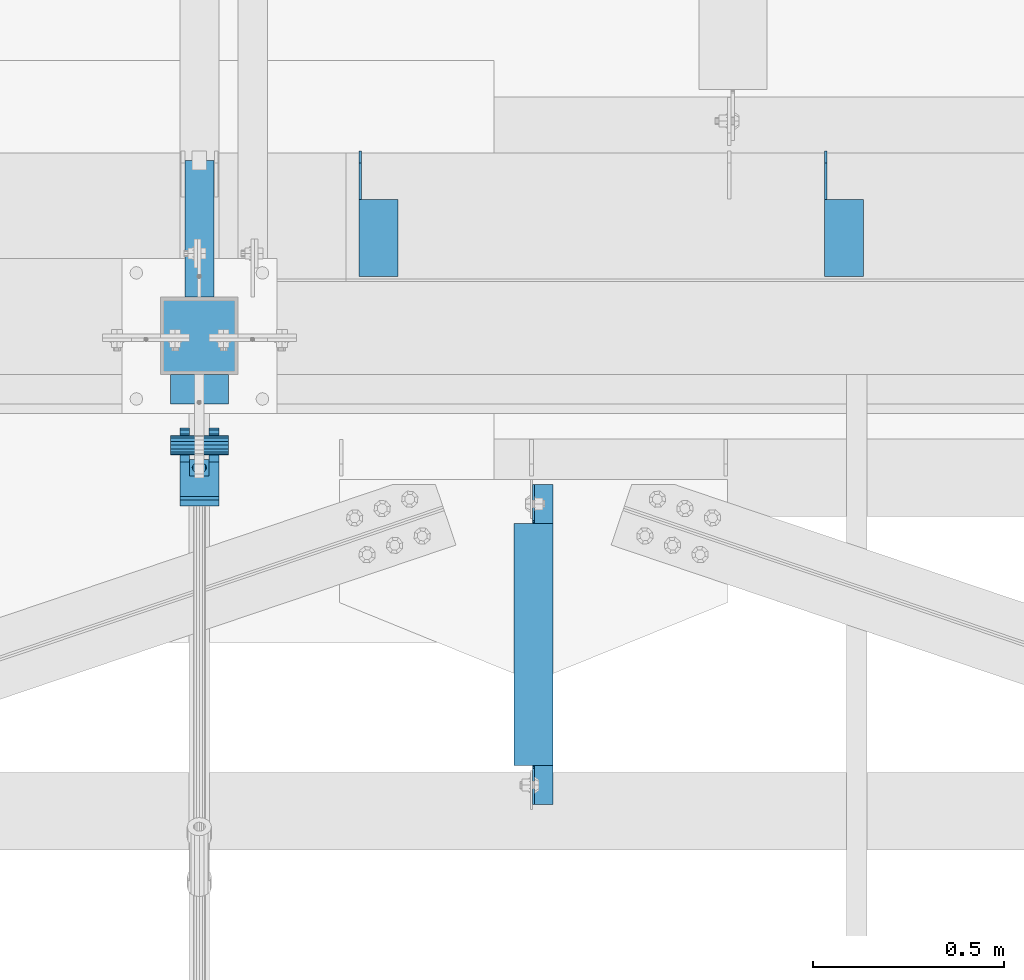
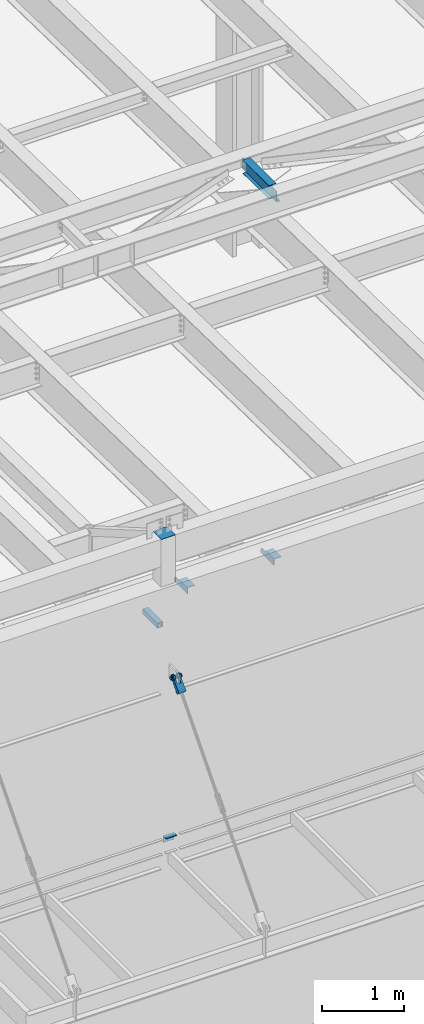
# One storey, part 1203 of 1763: 7 beams, 1 member, 6 elements without a shape of their own.
"""IFC2X3 building model written with IfcOpenShell, lengths in millimetres."""

from ifc_helpers import new_model, si_unit, frame, origin_with_axes, place, context, subcontext, project, spatial, faceted_brep, material, type_object, element, aggregate, save


model = new_model("IFC2X3")

# Units and contexts
model_context = context("Model", 3, precision=1e-05, world=origin_with_axes())
body_context = subcontext(model_context, "Body", "Model", "MODEL_VIEW")
ifc_project = project(units=[si_unit("LENGTHUNIT", "METRE", prefix="MILLI"), si_unit("AREAUNIT", "SQUARE_METRE"), si_unit("VOLUMEUNIT", "CUBIC_METRE"), si_unit("MASSUNIT", "GRAM", prefix="KILO"), si_unit("TIMEUNIT", "SECOND"), si_unit("PLANEANGLEUNIT", "RADIAN"), si_unit("SOLIDANGLEUNIT", "STERADIAN"), si_unit("THERMODYNAMICTEMPERATUREUNIT", "DEGREE_CELSIUS"), si_unit("LUMINOUSINTENSITYUNIT", "LUMEN")], contexts=[model_context])

# Site, building, storey
site_placement = place(None, origin_with_axes())
site = spatial("IfcSite", under=ifc_project, at=site_placement, CompositionType="ELEMENT")
building_placement = place(site_placement, origin_with_axes())
building = spatial("IfcBuilding", under=site, at=building_placement, Name="Undefined", CompositionType="ELEMENT")
storey_placement = place(building_placement, origin_with_axes())
storey = spatial("IfcBuildingStorey", under=building, at=storey_placement, Name="Undefined", CompositionType="ELEMENT", Elevation=0.0)

# Assembly, beams
assembly_1_placement = place(storey_placement, origin_with_axes())
assembly_1 = element("IfcElementAssembly", 1, at=assembly_1_placement, inside=storey, Name="BEAM", AssemblyPlace="NOTDEFINED", PredefinedType="RIGID_FRAME")
ifc_material_1 = material(Name="STEEL/A36")
beam_type_1 = type_object("IfcBeamType", Name="L4X4X1/4", PredefinedType="NOTDEFINED")
beam_1_placement = place(assembly_1_placement, frame((-57239.2055562795, -13723.1435701432, 12153.9), z_axis=(0.0, 0.0, -1.0), x_axis=(0.0, -1.0, 0.0)))
beam_1 = element("IfcBeam", 2, at=beam_1_placement, type_object=beam_type_1, material=ifc_material_1, Name="BRACE", ObjectType="L4X4X1/4", context=body_context, shape_type="Brep", body=[
    faceted_brep([(127.793748474227, 44.4499999999971, -31.7500007627295), (127.793748474227, 50.8000000000029, -31.7500007627295), (127.793748474225, 50.8000000000029, -50.7999999999993), (127.793748474225, -50.8000000000029, -50.7999999999993), (127.793748474225, -50.8000000000029, -44.4500000000007), (127.793748474225, 44.4499999999971, -44.4500000000007), (31.7499999999673, 44.4499999999971, -31.7500001906901), (31.7499999999673, 50.8000000000029, -31.7500007627295), (-1.81898940354586e-10, 44.4500000000371, 50.7999999999374), (-1.96450855582952e-10, 50.8000000000393, 50.7999999999374), (0.0, 50.8000000000029, -1.90690116141923e-07), (0.0, 44.4499999999971, -1.90690116141923e-07), (329.406260681253, 44.4499999999971, 50.7999999999993), (329.406260681253, 50.8000000000029, 50.7999999999993), (329.406260681253, 44.4499999999971, -44.4500000000007), (329.406260681253, -50.8000000000029, -44.4500000000007), (329.406260681253, -50.8000000000029, -50.7999999999993), (329.406260681253, 50.8000000000029, -50.7999999999993)], [[[0, 1, 2, 3, 4, 5]], [[1, 0, 6, 7]], [[8, 9, 10, 11]], [[9, 8, 12, 13]], [[12, 14, 15, 16, 17, 13]], [[15, 14, 5, 4]], [[16, 15, 4, 3]], [[17, 16, 3, 2]], [[9, 13, 17, 2, 1, 7, 10]], [[6, 11, 10, 7]], [[0, 5, 14, 12, 8, 11, 6]]]),
])
beam_2_placement = place(assembly_1_placement, frame((-58458.4055562795, -13723.1435701432, 12153.9), z_axis=(0.0, 0.0, -1.0), x_axis=(0.0, -1.0, 0.0)))
beam_2 = element("IfcBeam", 3, at=beam_2_placement, type_object=beam_type_1, material=ifc_material_1, Name="BRACE", ObjectType="L4X4X1/4", context=body_context, shape_type="Brep", body=[
    faceted_brep([(127.793748474227, 44.4499999999971, -31.7500007627295), (127.793748474227, 50.8000000000029, -31.7500007627295), (127.793748474225, 50.8000000000029, -50.7999999999993), (127.793748474225, -50.8000000000029, -50.7999999999993), (127.793748474225, -50.8000000000029, -44.4500000000007), (127.793748474225, 44.4499999999971, -44.4500000000007), (31.7499999999673, 44.4499999999971, -31.7500001906901), (31.7499999999673, 50.8000000000029, -31.7500007627295), (-1.81898940354586e-10, 44.4500000000371, 50.7999999999374), (-1.96450855582952e-10, 50.8000000000393, 50.7999999999374), (0.0, 50.8000000000029, -1.90690116141923e-07), (0.0, 44.4499999999971, -1.90690116141923e-07), (329.406260681253, 44.4499999999971, 50.7999999999993), (329.406260681253, 50.8000000000029, 50.7999999999993), (329.406260681253, 44.4499999999971, -44.4500000000007), (329.406260681253, -50.8000000000029, -44.4500000000007), (329.406260681253, -50.8000000000029, -50.7999999999993), (329.406260681253, 50.8000000000029, -50.7999999999993)], [[[0, 1, 2, 3, 4, 5]], [[1, 0, 6, 7]], [[8, 9, 10, 11]], [[9, 8, 12, 13]], [[12, 14, 15, 16, 17, 13]], [[15, 14, 5, 4]], [[16, 15, 4, 3]], [[17, 16, 3, 2]], [[9, 13, 17, 2, 1, 7, 10]], [[6, 11, 10, 7]], [[0, 5, 14, 12, 8, 11, 6]]]),
])
aggregate(assembly_1, [beam_1, beam_2])

# Assembly, beam
assembly_2_placement = place(storey_placement, origin_with_axes())
assembly_2 = element("IfcElementAssembly", 4, at=assembly_2_placement, inside=storey, Name="BEAM", AssemblyPlace="NOTDEFINED", PredefinedType="RIGID_FRAME")
ifc_material_2 = material()
beam_type_2 = type_object("IfcBeamType", Name="HSS3X3X1/4", PredefinedType="NOTDEFINED")
beam_3_placement = place(assembly_2_placement, frame((-58927.4270098567, -14106.5276214906, 11825.2875), z_axis=(0.0, 0.0, 1.0), x_axis=(0.0, 1.0, 0.0)))
beam_3 = element("IfcBeam", 5, at=beam_3_placement, type_object=beam_type_2, material=ifc_material_2, Name="BEAM", ObjectType="HSS3X3X1/4", context=body_context, shape_type="Brep", body=[
    faceted_brep([(0.0, 31.75, -31.75), (0.0, -31.75, -31.75), (357.9840528735, -31.75, -31.75), (357.9840528735, 31.75, -31.75), (0.0, -31.75, 31.75), (357.9840528735, -31.75, 31.75), (0.0, 31.75, 31.75), (357.9840528735, 31.75, 31.75), (0.0, 38.0999999999985, -38.1000000000004), (0.0, 38.0999999999985, 38.1000000000004), (357.9840528735, 38.0999999999985, 38.1000000000004), (357.9840528735, 38.0999999999985, -38.1000000000004), (0.0, -38.0999999999985, 38.1000000000004), (357.9840528735, -38.0999999999985, 38.1000000000004), (0.0, -38.0999999999985, -38.1000000000004), (357.9840528735, -38.0999999999985, -38.1000000000004)], [[[0, 1, 2, 3]], [[1, 4, 5, 2]], [[4, 6, 7, 5]], [[6, 0, 3, 7]], [[8, 9, 10, 11]], [[9, 12, 13, 10]], [[12, 14, 15, 13]], [[14, 8, 11, 15]], [[13, 15, 11, 10], [5, 7, 3, 2]], [[14, 12, 9, 8], [6, 4, 1, 0]]]),
])
aggregate(assembly_2, [beam_3])

assembly_3_placement = place(storey_placement, origin_with_axes())
assembly_3 = element("IfcElementAssembly", 6, at=assembly_3_placement, inside=storey, Name="BEAM", AssemblyPlace="NOTDEFINED", PredefinedType="RIGID_FRAME")
ifc_material_3 = material(Name="STEEL/A992")
beam_type_3 = type_object("IfcBeamType", Name="W8X10", PredefinedType="NOTDEFINED")
beam_4_placement = place(assembly_3_placement, frame((-58052.1858637093, -15452.7273151462, 18721.3875), z_axis=(0.0, 0.0, 1.0), x_axis=(0.0, 1.0, 0.0)))
beam_4 = element("IfcBeam", 7, at=beam_4_placement, type_object=beam_type_3, material=ifc_material_3, Name="BEAM", ObjectType="W8X10", context=body_context, shape_type="Brep", body=[
    faceted_brep([(119.062651889202, 2.68111246564513, -95.25), (119.062651888697, 2.68138385671773, -100.012500000001), (17.4625524882249, 2.68119447455683, -100.012500000001), (17.462552488254, 2.68092308348423, -95.25), (119.062558086149, 50.7999999995154, -95.25), (119.062558086149, 50.7999999995154, -100.012500000001), (119.062585395783, -2.38125000033324, 74.3525014877341), (119.062582114406, 2.38124999965657, 74.3525014877341), (118.095852191816, 2.38124999965657, 69.4924219696877), (118.095855473193, -2.38125000033324, 69.4924219696877), (115.342838291333, 2.38124999966385, 65.3722455015341), (115.342841572712, -2.38125000031869, 65.3722455015341), (111.222661823174, 2.38124999968568, 62.6192316010565), (111.222665104551, -2.38125000031141, 62.6192316010565), (106.362582305122, 2.38124999969295, 61.652501678469), (106.362585586499, -2.38125000029686, 61.652501678469), (17.4625525194206, 2.38124999996217, 61.652501678469), (17.4625530147059, -2.3812500000422, 61.652501678469), (17.4625530147059, -2.3812500000422, -95.25), (855.662553014712, -2.3812500022832, -95.25), (855.662553014712, -2.3812500022832, 61.652501678469), (766.762586825173, -2.38125000221044, 61.652501678469), (761.902507307121, -2.38125000219588, 62.6192316010565), (757.78233083896, -2.38125000218133, 65.3722455015341), (755.02931693848, -2.38125000217406, 69.4924219696877), (754.062587015891, -2.38125000216678, 74.3525014877341), (754.062587015991, -2.38125000216678, 95.25), (119.062585395672, -2.38125000033324, 95.25), (17.4625580501142, -50.8000000000393, -95.25), (855.662558050122, -50.8000000022803, -95.25), (17.4625580501142, -50.8000000000393, -100.012500000001), (855.662558050122, -50.8000000022803, -100.012500000001), (754.06250467346, 2.68138277246908, -95.25), (754.06250467369, 2.68111138139648, -100.012500000001), (754.062463102084, 50.7999999976746, -100.012500000001), (754.062463102084, 50.7999999976746, -95.25), (855.662552488204, 2.68146872577199, -95.25), (855.662552488233, 2.68119733469939, -100.012500000001), (855.662552519427, 2.38124999772117, -95.25), (855.662552519427, 2.38124999772117, 61.652501678469), (766.762583543798, 2.38124999777938, 61.652501678469), (761.902504025744, 2.38124999779393, 62.6192316010565), (757.782327557585, 2.38124999780848, 65.3722455015341), (755.029313657102, 2.38124999781576, 69.4924219696877), (754.062583734514, 2.38124999781576, 74.3525014877341), (754.062552665271, -50.8000000020038, 100.012500000001), (754.062552665271, -50.8000000020038, 95.25), (754.062583734623, 2.38124999781576, 95.25), (754.062550374047, 50.7999999976746, 95.25), (754.062550374047, 50.7999999976746, 100.012500000001), (119.062582114304, 2.38124999965657, 95.25), (119.062548753725, 50.7999999995227, 95.25), (119.062548753725, 50.7999999995227, 100.012500000001), (119.062552665697, -50.8000000003085, 100.012500000001), (119.062552665697, -50.8000000003085, 95.25), (17.4625525194206, 2.38124999996217, -95.25)], [[[0, 1, 2, 3]], [[4, 5, 1, 0]], [[6, 7, 8, 9]], [[9, 8, 10, 11]], [[11, 10, 12, 13]], [[13, 12, 14, 15]], [[15, 14, 16, 17]], [[9, 11, 13, 15, 17, 18, 19, 20, 21, 22, 23, 24, 25, 26, 27, 6]], [[18, 28, 29, 19]], [[28, 30, 31, 29]], [[32, 33, 34, 35]], [[36, 37, 33, 32]], [[38, 39, 20, 19, 29, 31, 37, 36]], [[20, 39, 40, 21]], [[21, 40, 41, 22]], [[22, 41, 42, 23]], [[23, 42, 43, 24]], [[24, 43, 44, 25]], [[45, 46, 26, 25, 44, 47, 48, 49]], [[48, 47, 50, 51]], [[49, 48, 51, 52]], [[45, 49, 52, 53]], [[46, 45, 53, 54]], [[26, 46, 54, 27]], [[53, 52, 51, 50, 7, 6, 27, 54]], [[47, 44, 43, 42, 41, 40, 39, 38, 55, 16, 14, 12, 10, 8, 7, 50]], [[30, 28, 18, 17, 16, 55, 3, 2]], [[34, 33, 37, 31, 30, 2, 1, 5]], [[35, 34, 5, 4]], [[55, 38, 36, 32, 35, 4, 0, 3]]]),
])
aggregate(assembly_3, [beam_4])

assembly_4_placement = place(storey_placement, origin_with_axes())
assembly_4 = element("IfcElementAssembly", 8, at=assembly_4_placement, inside=storey, Name="COLUMN", AssemblyPlace="NOTDEFINED", PredefinedType="RIGID_FRAME")
beam_type_4 = type_object("IfcBeamType", Name="L4X3X3/8", PredefinedType="NOTDEFINED")
beam_5_placement = place(assembly_4_placement, frame((-58851.2270126776, -14347.8276396054, 8788.4), z_axis=(0.0, 0.0, -1.0), x_axis=(-1.0, 0.0, 0.0)))
beam_5 = element("IfcBeam", 9, at=beam_5_placement, type_object=beam_type_4, material=ifc_material_1, Name="ANGLE", ObjectType="L4X3X3/8", context=body_context, shape_type="Brep", body=[
    faceted_brep([(1.45519152283669e-10, 38.0999999999985, -50.7999999999993), (1.45519152283669e-10, 38.0999999999985, 50.7999999999993), (152.400000000147, 38.1000000000186, 50.7999999999993), (152.400000000147, 38.1000000000186, -50.7999999999993), (1.09139364212751e-10, 28.5749999999989, 50.7999999999993), (152.400000000111, 28.5750000000171, 50.7999999999993), (1.09139364212751e-10, 28.5749999999989, -41.2749999999996), (152.400000000111, 28.5750000000171, -41.2749999999996), (-1.23691279441118e-10, -38.1000000000022, -41.2749999999996), (152.399999999878, -38.0999999999822, -41.2749999999996), (-1.23691279441118e-10, -38.1000000000022, -50.7999999999993), (152.399999999878, -38.0999999999822, -50.7999999999993)], [[[0, 1, 2, 3]], [[1, 4, 5, 2]], [[4, 6, 7, 5]], [[6, 8, 9, 7]], [[8, 10, 11, 9]], [[10, 0, 3, 11]], [[5, 7, 9, 11, 3, 2]], [[10, 8, 6, 4, 1, 0]]]),
])

assembly_5_placement = place(storey_placement, origin_with_axes())
assembly_5 = element("IfcElementAssembly", 10, at=assembly_5_placement, inside=storey, Name="PIN", AssemblyPlace="NOTDEFINED", PredefinedType="RIGID_FRAME")
beam_type_5 = type_object("IfcBeamType", PredefinedType="NOTDEFINED")
beam_6_placement = place(assembly_5_placement, frame((-59003.6270098567, -14493.8776228191, 11290.3000019096), z_axis=(0.0, 0.0, 1.0), x_axis=(1.0, 0.0, 0.0)))
beam_6 = element("IfcBeam", 11, at=beam_6_placement, type_object=beam_type_5, material=ifc_material_2, Name="PIN", context=body_context, shape_type="Brep", body=[
    faceted_brep([(0.0, -25.4000000000015, 0.0), (0.0, -23.466540125788, -9.72015918207308), (152.400103102711, -23.466540125788, -9.72015918207308), (152.400103102711, -25.4000000000015, 0.0), (0.0, -17.9605122421381, -17.9605122421385), (152.400103102711, -17.9605122421381, -17.9605122421385), (0.0, -9.72015918207398, -23.4665401257867), (152.400103102711, -9.72015918207398, -23.4665401257867), (0.0, 0.0, -25.4000000000001), (152.400103102711, 0.0, -25.4000000000001), (0.0, 9.72015918207398, -23.4665401257867), (152.400103102711, 9.72015918207398, -23.4665401257867), (0.0, 17.9605122421381, -17.9605122421385), (152.400103102711, 17.9605122421381, -17.9605122421385), (0.0, 23.466540125788, -9.72015918207308), (152.400103102711, 23.466540125788, -9.72015918207308), (0.0, 25.4000000000015, 0.0), (152.400103102711, 25.4000000000015, 0.0), (0.0, 23.466540125788, 9.72015918207308), (152.400103102711, 23.466540125788, 9.72015918207308), (0.0, 17.9605122421381, 17.9605122421385), (152.400103102711, 17.9605122421381, 17.9605122421385), (0.0, 9.72015918207398, 23.4665401257867), (152.400103102711, 9.72015918207398, 23.4665401257867), (0.0, 0.0, 25.4000000000001), (152.400103102711, 0.0, 25.4000000000001), (0.0, -9.72015918207398, 23.4665401257867), (152.400103102711, -9.72015918207398, 23.4665401257867), (0.0, -17.9605122421381, 17.9605122421385), (152.400103102711, -17.9605122421381, 17.9605122421385), (0.0, -23.466540125788, 9.72015918207308), (152.400103102711, -23.466540125788, 9.72015918207308)], [[[0, 1, 2, 3]], [[1, 4, 5, 2]], [[4, 6, 7, 5]], [[6, 8, 9, 7]], [[8, 10, 11, 9]], [[10, 12, 13, 11]], [[12, 14, 15, 13]], [[14, 16, 17, 15]], [[16, 18, 19, 17]], [[18, 20, 21, 19]], [[20, 22, 23, 21]], [[22, 24, 25, 23]], [[24, 26, 27, 25]], [[26, 28, 29, 27]], [[28, 30, 31, 29]], [[30, 0, 3, 31]], [[5, 7, 9, 11, 13, 15, 17, 19, 21, 23, 25, 27, 29, 31, 3, 2]], [[30, 28, 26, 24, 22, 20, 18, 16, 14, 12, 10, 8, 6, 4, 1, 0]]]),
])
aggregate(assembly_5, [beam_6])

# Assembly, member
assembly_6_placement = place(storey_placement, origin_with_axes())
assembly_6 = element("IfcElementAssembly", 12, at=assembly_6_placement, inside=storey, Name="HANGER ROD", AssemblyPlace="NOTDEFINED", PredefinedType="RIGID_FRAME")
member_type = type_object("IfcMemberType", PredefinedType="NOTDEFINED")
member_placement = place(assembly_6_placement, frame((-58927.4270098567, -14464.5701432834, 11323.7196689226), z_axis=(-1.0, 0.0, 0.0), x_axis=(0.0, -0.659331697240892, -0.751852188274693)))
member = element("IfcMember", 13, at=member_placement, type_object=member_type, material=ifc_material_1, context=body_context, shape_type="Brep", body=[
    faceted_brep([(254.000002114522, 9.52500000169675, 16.4977839419953), (134.273330688089, 9.52500000160944, 16.4977839419953), (134.273330688083, 16.4977839436942, 9.52499999989959), (254.000002182145, 16.4977839437852, 9.52499999989959), (134.273330688081, 19.0500000015963, -1.01863406598568e-10), (254.000002023278, 19.0500000016909, -1.01863406598568e-10), (134.273330688083, 16.4977839436942, -9.52500000010332), (254.000001680489, 16.4977839437852, -9.52500000010332), (134.273330688089, 9.52500000160944, -16.497783942199), (254.000001245629, 9.52500000169675, -16.497783942199), (134.273330688098, 1.61890056915581e-09, -19.0500000001048), (254.000000835218, 1.70985003933311e-09, -19.0500000001048), (134.273330688103, -9.52499999837164, -16.497783942199), (254.000000559224, -9.52499999827705, -16.497783942199), (134.273330688109, -16.4977839404564, -9.52500000010332), (254.000000491603, -16.4977839403655, -9.52500000010332), (134.273330688112, -19.0499999983585, -1.01863406598568e-10), (254.000000650468, -19.0499999982676, -1.01863406598568e-10), (134.273330688109, -16.4977839404564, 9.52499999989959), (254.000000993259, -16.4977839403655, 9.52499999989959), (134.273330688103, -9.52499999837164, 16.4977839419953), (254.000001428119, -9.52499999827705, 16.4977839419953), (134.273330688098, 1.61890056915581e-09, 19.049999999901), (254.00000183853, 1.70985003933311e-09, 19.049999999901), (78.4980859522016, 28.5827170717785, -50.8000000000029), (71.5070499125045, 35.2741161661834, -50.8000000000029), (71.5070499125045, 35.2741161661834, -25.3999992370664), (78.4980859522016, 28.5827170717785, -25.3999992370664), (63.2335594920528, 40.2939531168813, -50.8000000000029), (63.2335594920528, 40.2939531168813, -25.3999992370664), (54.0697628847552, 43.4042969063921, -50.8000000000029), (54.0697628847552, 43.4042969063921, -25.3999992370664), (44.4500000032872, 44.4500000000189, -50.8000000000029), (44.4500000032872, 44.4500000003973, -25.3999992370664), (27.4397209215654, 41.0664449477481, -50.8000000000029), (27.4397209215654, 41.0664449477481, -25.3999992370664), (13.0191026972475, 31.4308957019275, -50.8000000000029), (13.0191026972475, 31.4308957019275, -25.3999992370664), (3.38355373177319, 17.0102772902901, -50.8000000000029), (3.38355373177319, 17.0102772902901, -25.3999992370664), (0.0, 0.0, -50.7999992370605), (0.0, 0.0, -25.4000000000001), (3.38355545789955, -17.0102785002382, -50.8000000000029), (3.38355545789955, -17.0102785002382, -25.3999992370664), (13.0191044786457, -31.4308962839314, -50.8000000000029), (13.0191044786457, -31.4308962839314, -25.3999992370664), (27.4397222623497, -41.066445304652, -50.8000000000029), (27.4397222623497, -41.066445304652, -25.3999992370664), (44.4500007625898, -44.4499999999498, -50.8000000000029), (44.4500007625898, -44.4500001906781, -25.3999992370664), (54.0697566383383, -43.3965760809588, -50.8000000000029), (54.0697566383383, -43.3965760809588, -25.3999992370664), (63.2335536920523, -40.2862336066682, -50.8000000000029), (63.2335536920523, -40.2862336066682, -25.3999992370664), (71.507044832973, -35.266397843403, -50.8000000000029), (71.507044832973, -35.266397843403, -25.3999992370664), (78.4980818330437, -28.5749997523744, -50.8000000000029), (78.4980818330437, -28.5749997523744, -25.3999992370664), (71.5070499125045, 35.2741161661834, 50.8000000000029), (78.4980859522016, 28.5827170717785, 50.8000000000029), (78.4980859522016, 28.5827170717785, 25.3999999999942), (71.5070499125045, 35.2741161661834, 25.3999999999942), (63.2335594920528, 40.2939531168813, 50.8000000000029), (63.2335594920528, 40.2939531168813, 25.3999999999942), (54.0697628847552, 43.4042969063921, 50.8000000000029), (54.0697628847552, 43.4042969063921, 25.3999999999942), (44.4500000032872, 44.4500000015396, 50.8000000000029), (44.450000003289, 44.4500000011612, 25.3999999999942), (27.4397209215654, 41.0664449477481, 50.8000000000029), (27.4397209215654, 41.0664449477481, 25.3999999999942), (13.0191026972475, 31.4308957019275, 50.8000000000029), (13.0191026972475, 31.4308957019275, 25.3999999999942), (3.38355373177319, 17.0102772902901, 50.8000000000029), (3.38355373177319, 17.0102772902901, 25.3999999999942), (0.0, 0.0, 50.7999992370605), (0.0, 0.0, 25.4000000000001), (3.38355545789955, -17.0102785002382, 50.8000000000029), (3.38355545789955, -17.0102785002382, 25.3999999999942), (13.0191044786457, -31.4308962839314, 50.8000000000029), (13.0191044786457, -31.4308962839314, 25.3999999999942), (27.4397222623497, -41.066445304652, 50.8000000000029), (27.4397222623497, -41.066445304652, 25.3999999999942), (44.4500007625898, -44.4500007628594, 50.8000000000029), (44.4500007625898, -44.4500005721347, 25.3999999999942), (54.0697566383383, -43.3965760809588, 50.8000000000029), (54.0697566383383, -43.3965760809588, 25.3999999999942), (63.2335536920523, -40.2862336066682, 50.8000000000029), (63.2335536920523, -40.2862336066682, 25.3999999999942), (71.507044832973, -35.266397843403, 50.8000000000029), (71.507044832973, -35.266397843403, 25.3999999999942), (78.4980818330437, -28.5749997523744, 50.8000000000029), (78.4980818330437, -28.5749997523744, 25.3999999999942), (215.900005804647, -28.5749978020685, -50.8000000000029), (215.900005804647, -28.5749978020685, 50.8000000000029), (134.273330688118, -28.574998960692, 25.3999999999942), (134.273330688118, -28.574998960692, -25.3999992370664), (215.899998542161, -41.274998426099, -50.8000000000029), (215.899998542161, -41.274998426099, 50.8000000000029), (254.000000615249, -28.5749978178974, 50.8000000000029), (253.999999999285, -28.5749978178974, -50.8000000000029), (253.999999999241, 28.5826899486601, -50.8000000000029), (254.000004734274, 28.5826899486601, 50.8000000000029), (215.900009923701, 28.5826954010772, 50.8000000000029), (215.900004483963, 41.2826960251004, 50.8000000000029), (65.3837779449618, -23.8713099949055, 50.8000000000029), (54.6551341370573, -30.0652247148719, 50.8000000000029), (42.3728511665136, -31.6819815137387, 50.8000000000029), (30.4067952764267, -28.4754438248128, 50.8000000000029), (20.5786900034959, -20.9337779439011, 50.8000000000029), (14.3847752835277, -10.2051341359947, 50.8000000000029), (12.7680184846608, 2.07714883454901, 50.8000000000029), (15.9745561735849, 14.0432047246359, 50.8000000000029), (23.5162220544985, 23.8713099975648, 50.8000000000029), (34.2448658624066, 30.0652247175349, 50.8000000000029), (46.5271488329486, 31.6819815164017, 50.8000000000029), (58.4932047230354, 28.4754438274795, 50.8000000000029), (68.3213099959662, 20.9337779465641, 50.8000000000029), (74.5152247159344, 10.2051341386577, 50.8000000000029), (76.1319815147995, -2.07714883188601, 50.8000000000029), (72.9254438258772, -14.0432047219729, 50.8000000000029), (65.3837779449618, -23.8713099949055, 25.3999999999942), (54.6551341370573, -30.0652247148719, 25.3999999999942), (42.3728511665136, -31.6819815137387, 25.3999999999942), (30.4067952764267, -28.4754438248128, 25.3999999999942), (20.5786900034959, -20.9337779439011, 25.3999999999942), (14.3847752835277, -10.2051341359947, 25.3999999999942), (12.7680184846608, 2.07714883454901, 25.3999999999942), (15.9745561735849, 14.0432047246359, 25.3999999999942), (23.5162220544985, 23.8713099975648, 25.3999999999942), (34.2448658624066, 30.0652247175349, 25.3999999999942), (46.5271488329486, 31.6819815164017, 25.3999999999942), (58.4932047230354, 28.4754438274795, 25.3999999999942), (68.3213099959662, 20.9337779465641, 25.3999999999942), (74.5152247159344, 10.2051341386577, 25.3999999999942), (76.1319815147995, -2.07714883188601, 25.3999999999942), (72.9254438258772, -14.0432047219729, 25.3999999999942), (134.273330688074, 28.5827082750402, 25.3999999999942), (215.900009923701, 28.5826954010772, -50.8000000000029), (134.273330688074, 28.5827082750402, -25.3999992370664), (215.900004483963, 41.2826960251004, -50.8000000000029), (68.3213099959662, 20.9337779465641, -50.8000000000029), (58.4932047230354, 28.4754438274795, -50.8000000000029), (46.5271488329486, 31.6819815164017, -50.8000000000029), (34.2448658624066, 30.0652247175349, -50.8000000000029), (23.5162220544985, 23.8713099975648, -50.8000000000029), (15.9745561735849, 14.0432047246359, -50.8000000000029), (12.7680184846608, 2.07714883454901, -50.8000000000029), (14.3847752835277, -10.2051341359947, -50.8000000000029), (20.5786900034959, -20.9337779439011, -50.8000000000029), (30.4067952764267, -28.4754438248128, -50.8000000000029), (42.3728511665136, -31.6819815137387, -50.8000000000029), (54.6551341370573, -30.0652247148719, -50.8000000000029), (65.3837779449618, -23.8713099949055, -50.8000000000029), (72.9254438258772, -14.0432047219729, -50.8000000000029), (76.1319815147995, -2.07714883188601, -50.8000000000029), (74.5152247159344, 10.2051341386577, -50.8000000000029), (68.3213099959662, 20.9337779465641, -25.3999992370664), (58.4932047230354, 28.4754438274795, -25.3999992370664), (46.5271488329486, 31.6819815164017, -25.3999992370664), (34.2448658624066, 30.0652247175349, -25.3999992370664), (23.5162220544985, 23.8713099975648, -25.3999992370664), (15.9745561735849, 14.0432047246359, -25.3999992370664), (12.7680184846608, 2.07714883454901, -25.3999992370664), (14.3847752835277, -10.2051341359947, -25.3999992370664), (20.5786900034959, -20.9337779439011, -25.3999992370664), (30.4067952764267, -28.4754438248128, -25.3999992370664), (42.3728511665136, -31.6819815137387, -25.3999992370664), (54.6551341370573, -30.0652247148719, -25.3999992370664), (65.3837779449618, -23.8713099949055, -25.3999992370664), (72.9254438258772, -14.0432047219729, -25.3999992370664), (76.1319815147995, -2.07714883188601, -25.3999992370664), (74.5152247159344, 10.2051341386577, -25.3999992370664)], [[[0, 1, 2, 3]], [[3, 2, 4, 5]], [[5, 4, 6, 7]], [[7, 6, 8, 9]], [[9, 8, 10, 11]], [[11, 10, 12, 13]], [[13, 12, 14, 15]], [[15, 14, 16, 17]], [[17, 16, 18, 19]], [[19, 18, 20, 21]], [[21, 20, 22, 23]], [[23, 22, 1, 0]], [[24, 25, 26, 27]], [[25, 28, 29, 26]], [[28, 30, 31, 29]], [[30, 32, 33, 31]], [[32, 34, 35, 33]], [[34, 36, 37, 35]], [[36, 38, 39, 37]], [[38, 40, 41, 39]], [[40, 42, 43, 41]], [[42, 44, 45, 43]], [[44, 46, 47, 45]], [[46, 48, 49, 47]], [[48, 50, 51, 49]], [[50, 52, 53, 51]], [[52, 54, 55, 53]], [[54, 56, 57, 55]], [[58, 59, 60, 61]], [[62, 58, 61, 63]], [[64, 62, 63, 65]], [[66, 64, 65, 67]], [[68, 66, 67, 69]], [[70, 68, 69, 71]], [[72, 70, 71, 73]], [[74, 72, 73, 75]], [[76, 74, 75, 77]], [[78, 76, 77, 79]], [[80, 78, 79, 81]], [[82, 80, 81, 83]], [[84, 82, 83, 85]], [[86, 84, 85, 87]], [[88, 86, 87, 89]], [[90, 88, 89, 91]], [[57, 56, 92, 93, 90, 91, 94, 95]], [[93, 92, 96, 97]], [[98, 97, 96, 99]], [[98, 99, 100, 101], [3, 5, 7, 9, 11, 13, 15, 17, 19, 21, 23, 0]], [[102, 59, 58, 62, 64, 66, 68, 70, 72, 74, 76, 78, 80, 82, 84, 86, 88, 90, 93, 97, 98, 101, 103], [104, 105, 106, 107, 108, 109, 110, 111, 112, 113, 114, 115, 116, 117, 118, 119]], [[105, 104, 120, 121]], [[106, 105, 121, 122]], [[107, 106, 122, 123]], [[108, 107, 123, 124]], [[109, 108, 124, 125]], [[110, 109, 125, 126]], [[111, 110, 126, 127]], [[112, 111, 127, 128]], [[113, 112, 128, 129]], [[114, 113, 129, 130]], [[115, 114, 130, 131]], [[116, 115, 131, 132]], [[117, 116, 132, 133]], [[118, 117, 133, 134]], [[119, 118, 134, 135]], [[104, 119, 135, 120]], [[91, 89, 87, 85, 83, 81, 79, 77, 75, 73, 71, 69, 67, 65, 63, 61, 60, 136, 94], [134, 133, 132, 131, 130, 129, 128, 127, 126, 125, 124, 123, 122, 121, 120, 135]], [[59, 102, 137, 24, 27, 138, 136, 60]], [[103, 139, 137, 102]], [[101, 100, 139, 103]], [[99, 96, 92, 56, 54, 52, 50, 48, 46, 44, 42, 40, 38, 36, 34, 32, 30, 28, 25, 24, 137, 139, 100], [140, 141, 142, 143, 144, 145, 146, 147, 148, 149, 150, 151, 152, 153, 154, 155]], [[141, 140, 156, 157]], [[142, 141, 157, 158]], [[143, 142, 158, 159]], [[144, 143, 159, 160]], [[145, 144, 160, 161]], [[146, 145, 161, 162]], [[147, 146, 162, 163]], [[148, 147, 163, 164]], [[149, 148, 164, 165]], [[150, 149, 165, 166]], [[151, 150, 166, 167]], [[152, 151, 167, 168]], [[153, 152, 168, 169]], [[154, 153, 169, 170]], [[155, 154, 170, 171]], [[140, 155, 171, 156]], [[95, 138, 27, 26, 29, 31, 33, 35, 37, 39, 41, 43, 45, 47, 49, 51, 53, 55, 57], [170, 169, 168, 167, 166, 165, 164, 163, 162, 161, 160, 159, 158, 157, 156, 171]], [[94, 136, 138, 95], [18, 16, 14, 12, 10, 8, 6, 4, 2, 1, 22, 20]]]),
])
aggregate(assembly_6, [member])

# Beam
beam_type_6 = type_object("IfcBeamType", PredefinedType="NOTDEFINED")
beam_7_placement = place(assembly_4_placement, frame((-58927.4270098567, -14309.7276214906, 13255.6471257957), z_axis=(1.0, 0.0, 0.0), x_axis=(0.0, 1.0, 0.0)))
beam_7 = element("IfcBeam", 14, at=beam_7_placement, type_object=beam_type_6, material=ifc_material_1, Name="PLATE", context=body_context, shape_type="Brep", body=[
    faceted_brep([(0.0, 3.1749999995518, -101.600000000005), (0.0, 3.17499999999927, 101.599998474121), (203.200000000001, 3.17500000054133, 101.600000000011), (203.200000000001, 3.1749999995518, -101.600000000005), (0.0, -3.17499999999927, 101.599998474121), (203.200000000001, -3.17499999950815, 101.600000000005), (0.0, -3.17500000051223, -101.600000000012), (203.200000000001, -3.17500000051223, -101.600000000012)], [[[0, 1, 2, 3]], [[1, 4, 5, 2]], [[4, 6, 7, 5]], [[6, 0, 3, 7]], [[5, 7, 3, 2]], [[6, 4, 1, 0]]]),
])

aggregate(assembly_4, [beam_5, beam_7])

save(model, "model.ifc")
